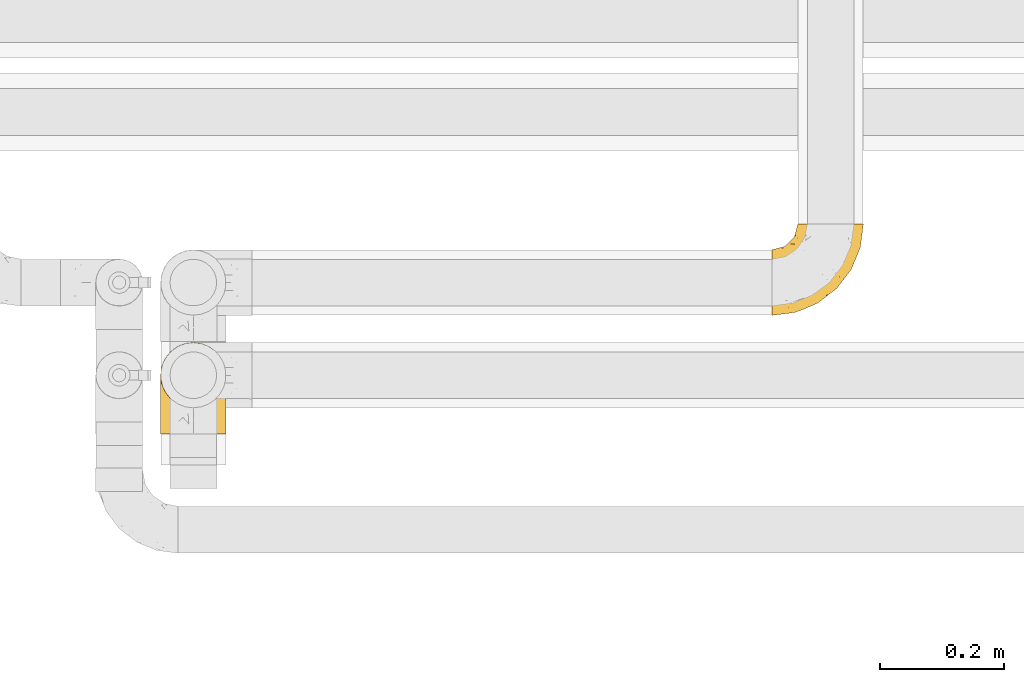
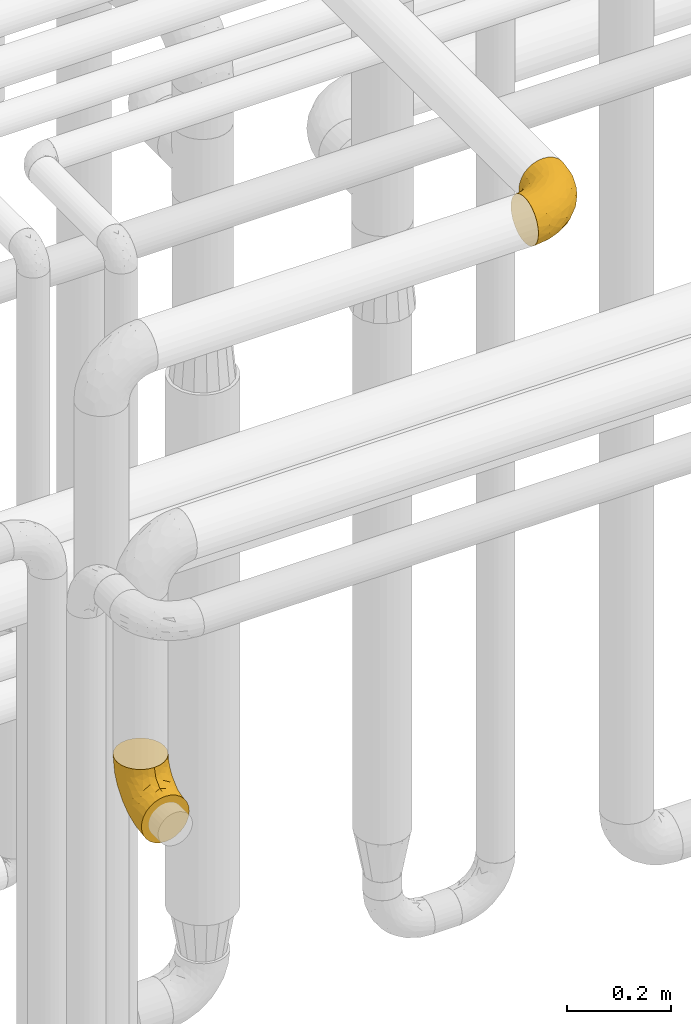
# One storey, part 440 of 827: 2 coverings.
"""IFC2X3 building model written with IfcOpenShell, lengths in millimetres."""

from ifc_helpers import new_model, entity, si_unit, converted_unit, derived_unit, direction, frame, origin, place, context, subcontext, project, spatial, faceted_brep, element, save


model = new_model("IFC2X3")

# Units and contexts
model_context = context("Model", 3, precision=0.01, world=origin(), true_north=direction((6.12303176911189e-17, 1.0)))
body_context = subcontext(model_context, "Body", "Model", "MODEL_VIEW")
ifc_project = project(units=[si_unit("LENGTHUNIT", "METRE", prefix="MILLI"), si_unit("AREAUNIT", "SQUARE_METRE"), si_unit("VOLUMEUNIT", "CUBIC_METRE"), converted_unit("PLANEANGLEUNIT", "DEGREE", entity("IfcRatioMeasure", 0.0174532925199433), si_unit("PLANEANGLEUNIT", "RADIAN"), dimensions=[0, 0, 0, 0, 0, 0, 0]), si_unit("MASSUNIT", "GRAM", prefix="KILO"), derived_unit("MASSDENSITYUNIT", [(si_unit("MASSUNIT", "GRAM", prefix="KILO"), 1), (si_unit("LENGTHUNIT", "METRE"), -3)]), derived_unit("MOMENTOFINERTIAUNIT", [(si_unit("LENGTHUNIT", "METRE"), 4)]), si_unit("TIMEUNIT", "SECOND"), si_unit("FREQUENCYUNIT", "HERTZ"), si_unit("THERMODYNAMICTEMPERATUREUNIT", "DEGREE_CELSIUS"), derived_unit("THERMALTRANSMITTANCEUNIT", [(si_unit("MASSUNIT", "GRAM", prefix="KILO"), 1), (si_unit("THERMODYNAMICTEMPERATUREUNIT", "KELVIN"), -1), (si_unit("TIMEUNIT", "SECOND"), -3)]), derived_unit("VOLUMETRICFLOWRATEUNIT", [(si_unit("LENGTHUNIT", "METRE"), 3), (si_unit("TIMEUNIT", "SECOND"), -1)]), derived_unit("MASSFLOWRATEUNIT", [(si_unit("MASSUNIT", "GRAM", prefix="KILO"), 1), (si_unit("TIMEUNIT", "SECOND"), -1)]), derived_unit("ROTATIONALFREQUENCYUNIT", [(si_unit("TIMEUNIT", "SECOND"), -1)]), si_unit("ELECTRICCURRENTUNIT", "AMPERE"), si_unit("ELECTRICVOLTAGEUNIT", "VOLT"), si_unit("POWERUNIT", "WATT"), si_unit("FORCEUNIT", "NEWTON", prefix="KILO"), si_unit("ILLUMINANCEUNIT", "LUX"), si_unit("LUMINOUSFLUXUNIT", "LUMEN"), si_unit("LUMINOUSINTENSITYUNIT", "CANDELA"), derived_unit("USERDEFINED", [(si_unit("MASSUNIT", "GRAM", prefix="KILO"), -1), (si_unit("LENGTHUNIT", "METRE"), -2), (si_unit("TIMEUNIT", "SECOND"), 3), (si_unit("LUMINOUSFLUXUNIT", "LUMEN"), 1)]), derived_unit("LINEARVELOCITYUNIT", [(si_unit("LENGTHUNIT", "METRE"), 1), (si_unit("TIMEUNIT", "SECOND"), -1)]), si_unit("PRESSUREUNIT", "PASCAL"), derived_unit("USERDEFINED", [(si_unit("LENGTHUNIT", "METRE"), -2), (si_unit("MASSUNIT", "GRAM", prefix="KILO"), 1), (si_unit("TIMEUNIT", "SECOND"), -2)]), derived_unit("LINEARFORCEUNIT", [(si_unit("MASSUNIT", "GRAM", prefix="KILO"), 1), (si_unit("LENGTHUNIT", "METRE"), 1), (si_unit("TIMEUNIT", "SECOND"), -2), (si_unit("LENGTHUNIT", "METRE"), -1)]), derived_unit("PLANARFORCEUNIT", [(si_unit("MASSUNIT", "GRAM", prefix="KILO"), 1), (si_unit("LENGTHUNIT", "METRE"), 1), (si_unit("TIMEUNIT", "SECOND"), -2), (si_unit("LENGTHUNIT", "METRE"), -2)])], contexts=[model_context])

# Site, building, storey
site_placement = place(None, origin())
site = spatial("IfcSite", under=ifc_project, at=site_placement, CompositionType="ELEMENT")
building_placement = place(site_placement, origin())
building = spatial("IfcBuilding", under=site, at=building_placement, CompositionType="ELEMENT")
storey_placement = place(building_placement, frame((0.0, 0.0, 28200.0)))
storey = spatial("IfcBuildingStorey", under=building, at=storey_placement, Name="08", CompositionType="ELEMENT", Elevation=28200.0)

# Coverings
covering_1_placement = place(storey_placement, frame((56690.79, 15591.56, 3345.35)))
element("IfcCovering", 1, at=covering_1_placement, inside=storey, Name=":ADSK_", ObjectType=":ADSK_", PredefinedType="INSULATION", context=body_context, shape_type="Brep", body=[
    faceted_brep([(148.32, 149.65, 66.44), (149.65, 149.65, 54.65), (148.31, 149.65, 42.84), (144.39, 149.65, 31.62), (138.06, 149.65, 21.56), (129.66, 149.65, 13.16), (119.6, 149.65, 6.84), (108.39, 149.65, 2.92), (96.6, 149.65, 1.6), (84.79, 149.65, 2.93), (73.57, 149.65, 6.85), (63.51, 149.65, 13.18), (55.11, 149.65, 21.58), (48.79, 149.65, 31.64), (44.87, 149.65, 42.85), (43.55, 149.65, 54.65), (44.88, 149.65, 66.46), (48.8, 149.65, 77.67), (55.13, 149.65, 87.73), (63.53, 149.65, 96.13), (73.59, 149.65, 102.45), (84.8, 149.65, 106.37), (96.6, 149.65, 107.7), (108.41, 149.65, 106.36), (119.62, 149.65, 102.44), (129.68, 149.65, 96.11), (138.08, 149.65, 87.71), (144.4, 149.65, 77.65), (1.6, 105.89, 40.91), (1.6, 100.59, 28.12), (1.6, 92.16, 17.13), (1.6, 81.17, 8.7), (1.6, 68.38, 3.4), (1.6, 54.65, 1.6), (1.6, 40.91, 3.4), (1.6, 28.12, 8.7), (1.6, 17.13, 17.13), (1.6, 8.7, 28.12), (1.6, 3.4, 40.91), (1.6, 1.6, 54.65), (1.6, 3.4, 68.38), (1.6, 8.7, 81.17), (1.6, 17.13, 92.16), (1.6, 28.12, 100.59), (1.6, 40.91, 105.89), (1.6, 54.65, 107.7), (1.6, 68.38, 105.89), (1.6, 81.17, 100.59), (1.6, 92.16, 92.16), (1.6, 100.59, 81.17), (1.6, 105.89, 68.38), (1.6, 107.7, 54.65), (27.97, 14.05, 85.53), (37.09, 9.45, 73.42), (58.27, 22.36, 83.77), (27.13, 4.7, 64.22), (39.91, 6.64, 54.65), (109.11, 81.47, 96.72), (94.41, 56.83, 93.36), (110.94, 64.02, 84.47), (89.69, 34.04, 71.37), (75.62, 21.43, 54.65), (106.28, 44.96, 54.65), (60.12, 49.8, 103.47), (41.41, 35.43, 100.91), (63.22, 42.1, 99.1), (32.05, 43.59, 105.43), (52.13, 57.88, 106.79), (123.27, 91.8, 89.81), (129.32, 88.01, 79.59), (138.3, 115.65, 81.29), (62.95, 18.94, 74.01), (55.89, 12.83, 64.14), (37.4, 24.96, 94.75), (144.6, 111.33, 54.65), (142.66, 113.8, 70.74), (117.85, 60.89, 68.3), (134.01, 86.24, 66.05), (89.25, 65.84, 100.73), (103.34, 124.58, 106.78), (113.52, 121.36, 103.6), (57.43, 72.79, 107.7), (44.19, 66.04, 107.7), (30.95, 59.29, 107.7), (77.98, 73.26, 106.07), (132.66, 121.69, 90.59), (121.52, 109.82, 97.43), (86.93, 40.11, 84.51), (68.4, 36.57, 93.3), (78.45, 93.81, 107.7), (67.94, 83.3, 107.7), (94.53, 136.6, 107.7), (91.95, 120.29, 107.7), (93.36, 99.11, 106.79), (85.2, 107.05, 107.7), (101.45, 91.12, 103.47), (129.81, 75.62, 54.65), (16.27, 56.97, 107.7), (42.46, 126.65, 76.99), (40.4, 116.55, 84.28), (49.71, 120.09, 91.11), (39.4, 76.06, 106.26), (31.26, 83.69, 102.6), (27.7, 71.88, 106.08), (16.7, 66.92, 106.56), (70.67, 110.43, 105.36), (81.69, 121.31, 106.74), (16.68, 81.0, 101.59), (22.57, 113.32, 54.65), (14.26, 111.09, 54.65), (17.68, 109.14, 67.71), (19.58, 95.86, 91.36), (33.49, 99.07, 94.33), (33.01, 106.92, 87.1), (40.69, 131.39, 65.84), (40.15, 136.98, 54.65), (37.93, 128.67, 54.65), (31.04, 117.07, 68.92), (45.29, 96.39, 100.82), (23.55, 106.61, 79.83), (11.36, 103.72, 77.13), (59.1, 92.14, 105.9), (57.42, 107.13, 101.53), (68.96, 98.03, 106.72), (20.38, 88.38, 97.75), (72.46, 130.66, 103.08), (83.66, 135.45, 106.39), (60.66, 123.57, 98.1), (61.01, 137.75, 95.02), (51.85, 133.2, 86.9), (46.07, 138.8, 74.42), (30.25, 120.99, 54.65), (46.65, 84.53, 105.28), (43.0, 108.72, 92.87), (19.58, 95.86, 17.93), (72.44, 130.67, 6.22), (17.67, 109.13, 41.58), (78.45, 93.81, 1.6), (68.97, 98.02, 2.57), (70.65, 110.43, 3.94), (40.69, 131.4, 43.46), (42.45, 126.66, 32.32), (31.04, 117.08, 40.38), (42.99, 108.74, 16.44), (45.18, 96.31, 8.47), (33.46, 99.11, 15.01), (60.64, 123.58, 11.21), (57.37, 107.12, 7.78), (57.43, 72.79, 1.6), (44.19, 66.04, 1.6), (39.35, 76.07, 3.04), (16.27, 56.97, 1.6), (16.7, 66.92, 2.73), (91.95, 120.29, 1.6), (85.2, 107.05, 1.6), (81.68, 121.26, 2.55), (46.68, 84.46, 3.98), (31.26, 83.69, 6.69), (16.68, 81.0, 7.7), (27.7, 71.88, 3.21), (60.99, 137.76, 14.28), (51.84, 133.21, 22.42), (40.41, 116.58, 25.02), (49.72, 120.1, 18.18), (46.06, 138.81, 34.89), (94.53, 136.6, 1.6), (11.35, 103.72, 32.17), (33.02, 106.96, 22.23), (83.65, 135.44, 2.91), (20.38, 88.38, 11.54), (67.94, 83.3, 1.6), (23.53, 106.6, 29.46), (59.12, 92.12, 3.38), (30.95, 59.29, 1.6), (58.27, 22.36, 25.52), (27.97, 14.05, 23.76), (37.4, 24.96, 14.54), (41.41, 35.43, 8.38), (27.21, 4.71, 45.07), (37.09, 9.45, 35.87), (53.2, 11.79, 45.14), (52.13, 57.88, 2.5), (103.34, 124.57, 2.51), (113.5, 121.37, 5.68), (101.45, 91.12, 5.82), (94.41, 56.83, 15.93), (109.08, 81.48, 12.54), (110.95, 64.05, 24.81), (93.36, 99.11, 2.5), (77.98, 73.26, 3.22), (32.05, 43.59, 3.86), (64.63, 19.5, 35.85), (123.25, 91.8, 19.47), (132.65, 121.7, 18.68), (129.32, 88.04, 29.68), (139.96, 123.34, 27.95), (117.85, 60.89, 40.99), (89.69, 34.04, 37.92), (121.51, 109.85, 11.85), (63.23, 42.1, 10.19), (89.17, 65.78, 8.55), (142.66, 113.81, 38.53), (68.4, 36.57, 15.99), (86.94, 40.12, 24.79), (60.12, 49.8, 5.82), (133.2, 86.08, 40.56)], [[[0, 1, 2, 3, 4, 5, 6, 7, 8, 9, 10, 11, 12, 13, 14, 15, 16, 17, 18, 19, 20, 21, 22, 23, 24, 25, 26, 27]], [[28, 29, 30, 31, 32, 33, 34, 35, 36, 37, 38, 39, 40, 41, 42, 43, 44, 45, 46, 47, 48, 49, 50, 51]], [[52, 53, 54]], [[55, 39, 56]], [[57, 58, 59]], [[60, 61, 62]], [[63, 64, 65]], [[66, 63, 67]], [[68, 69, 70]], [[53, 71, 54]], [[41, 40, 53]], [[53, 72, 71]], [[73, 42, 52]], [[42, 41, 52]], [[74, 0, 75]], [[69, 76, 77]], [[43, 73, 64]], [[45, 44, 66]], [[57, 78, 58]], [[23, 79, 80]], [[67, 81, 82, 83]], [[67, 84, 81]], [[24, 23, 80]], [[25, 85, 26]], [[86, 85, 25]], [[42, 73, 43]], [[0, 27, 75]], [[25, 24, 86]], [[70, 26, 85]], [[0, 74, 1]], [[68, 85, 86]], [[66, 64, 63]], [[60, 59, 87]], [[54, 87, 88]], [[76, 60, 62]], [[84, 89, 90, 81]], [[79, 22, 91, 92]], [[77, 74, 75]], [[93, 92, 94, 89]], [[80, 86, 24]], [[40, 55, 53]], [[76, 59, 60]], [[93, 84, 95]], [[76, 62, 96]], [[55, 72, 53]], [[70, 27, 26]], [[75, 70, 69]], [[78, 84, 63]], [[93, 79, 92]], [[95, 86, 80]], [[77, 76, 96]], [[59, 69, 68]], [[57, 68, 86]], [[68, 57, 59]], [[59, 58, 87]], [[76, 69, 59]], [[88, 87, 58]], [[87, 54, 71]], [[86, 95, 57]], [[78, 57, 95]], [[84, 78, 95]], [[78, 63, 65]], [[58, 78, 65]], [[54, 88, 73]], [[84, 93, 89]], [[79, 95, 80]], [[79, 93, 95]], [[22, 79, 23]], [[66, 83, 97, 45]], [[84, 67, 63]], [[83, 66, 67]], [[64, 44, 43]], [[64, 66, 44]], [[65, 73, 88]], [[53, 52, 41]], [[73, 52, 54]], [[73, 65, 64]], [[65, 88, 58]], [[39, 55, 40]], [[72, 55, 56]], [[56, 61, 72]], [[60, 72, 61]], [[72, 60, 71]], [[87, 71, 60]], [[27, 70, 75]], [[68, 70, 85]], [[74, 77, 96]], [[69, 77, 75]], [[98, 99, 100]], [[46, 45, 97]], [[101, 102, 103]], [[103, 104, 83]], [[105, 94, 106]], [[107, 103, 102]], [[108, 109, 51, 110]], [[111, 112, 113]], [[114, 115, 116]], [[47, 104, 107]], [[110, 117, 108]], [[49, 48, 111]], [[102, 118, 112]], [[119, 120, 111]], [[50, 49, 120]], [[121, 122, 118]], [[105, 123, 89]], [[124, 48, 107]], [[20, 19, 125]], [[121, 81, 90]], [[117, 119, 99]], [[21, 20, 126]], [[22, 21, 91]], [[105, 125, 127]], [[110, 51, 50]], [[19, 128, 125]], [[16, 15, 115]], [[129, 98, 100]], [[126, 91, 21]], [[128, 129, 127]], [[122, 123, 105]], [[114, 117, 98]], [[17, 16, 130]], [[18, 128, 19]], [[129, 18, 17]], [[125, 106, 126]], [[115, 114, 16]], [[130, 129, 17]], [[114, 98, 130]], [[117, 116, 131, 108]], [[99, 119, 113]], [[122, 121, 123]], [[92, 126, 106]], [[105, 127, 122]], [[132, 121, 118]], [[114, 130, 16]], [[129, 130, 98]], [[50, 120, 110]], [[129, 128, 18]], [[125, 128, 127]], [[125, 126, 20]], [[91, 126, 92]], [[105, 89, 94]], [[105, 106, 125]], [[94, 92, 106]], [[100, 122, 127]], [[118, 122, 133]], [[112, 118, 133]], [[132, 118, 102]], [[132, 102, 101]], [[81, 121, 132]], [[82, 103, 83]], [[132, 101, 81]], [[104, 47, 46]], [[124, 107, 102]], [[48, 47, 107]], [[113, 112, 133]], [[112, 111, 124]], [[99, 113, 133]], [[111, 113, 119]], [[99, 133, 100]], [[117, 99, 98]], [[122, 100, 133]], [[127, 129, 100]], [[103, 82, 101]], [[81, 101, 82]], [[112, 124, 102]], [[48, 124, 111]], [[104, 103, 107]], [[46, 97, 104]], [[111, 120, 49]], [[83, 104, 97]], [[110, 120, 119]], [[117, 110, 119]], [[116, 117, 114]], [[89, 123, 90]], [[90, 123, 121]], [[30, 29, 134]], [[11, 10, 135]], [[51, 109, 108, 136]], [[137, 138, 139]], [[140, 141, 142]], [[143, 144, 145]], [[146, 139, 147]], [[148, 149, 150]], [[151, 32, 152]], [[153, 154, 155]], [[156, 150, 157]], [[158, 157, 159]], [[108, 142, 136]], [[31, 158, 152]], [[160, 161, 12]], [[162, 163, 143]], [[140, 142, 116]], [[142, 141, 162]], [[14, 164, 140]], [[14, 140, 115]], [[9, 8, 165]], [[160, 12, 11]], [[141, 164, 161]], [[13, 12, 161]], [[14, 115, 15]], [[28, 166, 29]], [[135, 139, 146]], [[141, 163, 162]], [[135, 146, 160]], [[143, 167, 162]], [[29, 166, 134]], [[116, 142, 108, 131]], [[165, 153, 168]], [[10, 9, 168]], [[168, 135, 10]], [[138, 147, 139]], [[158, 169, 157]], [[14, 13, 164]], [[116, 115, 140]], [[145, 167, 143]], [[135, 160, 11]], [[168, 153, 155]], [[138, 137, 170]], [[157, 144, 156]], [[147, 144, 143]], [[161, 164, 13]], [[140, 164, 141]], [[142, 171, 136]], [[136, 171, 166]], [[161, 160, 146]], [[165, 168, 9]], [[155, 139, 135]], [[139, 154, 137]], [[168, 155, 135]], [[139, 155, 154]], [[144, 147, 172]], [[163, 147, 143]], [[156, 144, 172]], [[157, 169, 145]], [[172, 148, 156]], [[173, 159, 149]], [[159, 157, 150]], [[152, 159, 173]], [[159, 152, 158]], [[31, 30, 158]], [[169, 30, 134]], [[157, 145, 144]], [[167, 134, 171]], [[134, 167, 145]], [[171, 142, 162]], [[162, 167, 171]], [[163, 141, 161]], [[161, 146, 163]], [[147, 163, 146]], [[148, 150, 156]], [[149, 159, 150]], [[30, 169, 158]], [[145, 169, 134]], [[151, 33, 32]], [[31, 152, 32]], [[152, 173, 151]], [[28, 51, 136]], [[134, 166, 171]], [[28, 136, 166]], [[138, 170, 172]], [[147, 138, 172]], [[148, 172, 170]], [[174, 175, 176]], [[35, 34, 177]], [[178, 179, 180]], [[181, 173, 149, 148]], [[182, 183, 184]], [[185, 186, 187]], [[188, 189, 137]], [[190, 33, 151, 173]], [[191, 179, 174]], [[34, 190, 177]], [[39, 38, 178]], [[192, 193, 194]], [[4, 3, 195]], [[175, 179, 37]], [[38, 37, 179]], [[35, 176, 36]], [[196, 62, 197]], [[181, 190, 173]], [[37, 36, 175]], [[183, 6, 198]], [[189, 148, 170, 137]], [[185, 199, 200]], [[3, 2, 201]], [[202, 185, 203]], [[8, 7, 182]], [[200, 184, 186]], [[183, 7, 6]], [[181, 189, 204]], [[200, 189, 184]], [[5, 198, 6]], [[187, 203, 185]], [[195, 3, 201]], [[205, 196, 194]], [[62, 61, 197]], [[186, 198, 192]], [[180, 179, 191]], [[2, 1, 74]], [[198, 193, 192]], [[193, 5, 4]], [[194, 193, 195]], [[2, 74, 201]], [[5, 193, 198]], [[205, 74, 96]], [[188, 137, 154, 153]], [[62, 196, 96]], [[56, 178, 180]], [[198, 184, 183]], [[184, 188, 182]], [[203, 197, 191]], [[205, 194, 201]], [[187, 192, 194]], [[192, 187, 186]], [[194, 196, 187]], [[197, 187, 196]], [[197, 203, 187]], [[202, 174, 176]], [[200, 186, 185]], [[184, 198, 186]], [[199, 185, 202]], [[189, 200, 204]], [[174, 202, 203]], [[176, 177, 199]], [[189, 181, 148]], [[190, 181, 204]], [[190, 204, 177]], [[190, 34, 33]], [[188, 153, 182]], [[189, 188, 184]], [[182, 153, 165, 8]], [[183, 182, 7]], [[199, 177, 204]], [[35, 177, 176]], [[176, 175, 36]], [[179, 175, 174]], [[200, 199, 204]], [[176, 199, 202]], [[203, 191, 174]], [[180, 197, 61]], [[197, 180, 191]], [[61, 56, 180]], [[39, 178, 56]], [[38, 179, 178]], [[194, 195, 201]], [[4, 195, 193]], [[74, 205, 201]], [[96, 196, 205]]]),
])
covering_2_placement = place(storey_placement, frame((55701.2, 15399.61, 2420.35)))
element("IfcCovering", 2, at=covering_2_placement, inside=storey, Name=":ADSK_", ObjectType=":ADSK_", PredefinedType="INSULATION", context=body_context, shape_type="Brep", body=[
    faceted_brep([(42.85, 1.6, 2.92), (54.65, 1.6, 1.6), (66.46, 1.6, 2.93), (77.67, 1.6, 6.85), (87.73, 1.6, 13.18), (96.13, 1.6, 21.58), (102.45, 1.6, 31.64), (106.37, 1.6, 42.85), (107.7, 1.6, 54.65), (106.36, 1.6, 66.46), (102.44, 1.6, 77.67), (96.11, 1.6, 87.73), (87.71, 1.6, 96.13), (77.65, 1.6, 102.45), (66.44, 1.6, 106.37), (54.65, 1.6, 107.7), (42.84, 1.6, 106.36), (31.62, 1.6, 102.44), (21.56, 1.6, 96.11), (13.16, 1.6, 87.71), (6.84, 1.6, 77.65), (2.92, 1.6, 66.44), (1.6, 1.6, 54.65), (2.93, 1.6, 42.84), (6.85, 1.6, 31.62), (13.18, 1.6, 21.56), (21.58, 1.6, 13.16), (31.64, 1.6, 6.84), (68.38, 45.35, 149.65), (81.17, 50.65, 149.65), (92.16, 59.08, 149.65), (100.59, 70.07, 149.65), (105.89, 82.86, 149.65), (107.7, 96.6, 149.65), (105.89, 110.33, 149.65), (100.59, 123.12, 149.65), (92.16, 134.11, 149.65), (81.17, 142.54, 149.65), (68.38, 147.84, 149.65), (54.65, 149.65, 149.65), (40.91, 147.84, 149.65), (28.12, 142.54, 149.65), (17.13, 134.11, 149.65), (8.7, 123.12, 149.65), (3.4, 110.33, 149.65), (1.6, 96.6, 149.65), (3.4, 82.86, 149.65), (8.7, 70.07, 149.65), (17.13, 59.08, 149.65), (28.12, 50.65, 149.65), (40.91, 45.35, 149.65), (54.65, 43.55, 149.65), (23.76, 137.19, 123.27), (35.87, 141.79, 114.15), (25.52, 128.89, 92.97), (45.07, 146.54, 124.11), (54.65, 144.6, 111.33), (12.57, 69.77, 42.13), (15.93, 94.41, 56.83), (24.82, 87.22, 40.31), (37.92, 117.2, 61.55), (54.65, 129.81, 75.62), (54.65, 106.28, 44.96), (5.82, 101.45, 91.12), (8.38, 115.81, 109.83), (10.19, 109.14, 88.02), (3.86, 107.65, 119.19), (2.5, 93.36, 99.11), (19.48, 59.44, 27.97), (29.7, 63.23, 21.92), (28.0, 35.59, 12.94), (35.28, 132.3, 88.29), (45.15, 138.41, 95.35), (14.54, 126.28, 113.84), (54.65, 39.91, 6.64), (38.55, 37.44, 8.58), (40.99, 90.35, 33.39), (43.24, 65.0, 17.23), (8.56, 85.4, 61.99), (2.51, 26.66, 47.9), (5.69, 29.88, 37.72), (1.6, 78.45, 93.81), (1.6, 85.2, 107.05), (1.6, 91.95, 120.29), (3.22, 77.98, 73.26), (18.7, 29.55, 18.58), (11.86, 41.42, 29.72), (24.78, 111.13, 64.31), (15.99, 114.67, 82.84), (1.6, 57.43, 72.79), (1.6, 67.94, 83.3), (1.6, 14.64, 56.71), (1.6, 30.95, 59.29), (2.5, 52.13, 57.88), (1.6, 44.19, 66.04), (5.82, 60.12, 49.8), (54.65, 75.62, 21.43), (1.6, 94.27, 134.97), (32.3, 24.59, 108.79), (25.01, 34.69, 110.84), (18.18, 31.15, 101.53), (3.03, 75.18, 111.84), (6.69, 67.55, 119.98), (3.21, 79.36, 123.54), (2.73, 84.32, 134.54), (3.93, 40.81, 80.57), (2.55, 29.93, 69.55), (7.7, 70.24, 134.56), (54.65, 37.93, 128.67), (54.65, 40.15, 136.98), (41.58, 42.1, 133.56), (17.93, 55.38, 131.66), (14.97, 52.17, 117.75), (22.2, 44.32, 118.23), (43.45, 19.85, 110.55), (54.65, 14.26, 111.09), (54.65, 22.57, 113.32), (40.37, 34.17, 120.2), (8.47, 54.85, 105.95), (29.46, 44.63, 127.69), (32.17, 47.52, 139.88), (3.39, 59.1, 92.14), (7.76, 44.11, 93.82), (2.57, 53.21, 82.28), (11.54, 62.86, 130.86), (6.21, 20.58, 78.78), (2.9, 15.79, 67.58), (11.19, 27.67, 90.58), (14.27, 13.49, 90.23), (22.4, 18.04, 99.39), (34.87, 12.44, 105.17), (54.65, 30.25, 120.99), (4.01, 66.71, 104.59), (16.42, 42.52, 108.24), (91.36, 55.38, 131.66), (103.07, 20.57, 78.8), (67.71, 42.11, 133.57), (107.7, 57.43, 72.79), (106.72, 53.22, 82.27), (105.35, 40.81, 80.59), (65.83, 19.85, 110.55), (76.97, 24.58, 108.79), (68.91, 34.16, 120.2), (92.85, 42.5, 108.25), (100.82, 54.93, 106.06), (94.28, 52.13, 117.78), (98.08, 27.66, 90.6), (101.51, 44.12, 93.87), (107.7, 78.45, 93.81), (107.7, 85.2, 107.05), (106.25, 75.17, 111.89), (107.7, 94.27, 134.97), (106.56, 84.32, 134.54), (107.7, 30.95, 59.29), (107.7, 44.19, 66.04), (106.74, 29.98, 69.56), (105.31, 66.78, 104.56), (102.6, 67.55, 119.98), (101.59, 70.24, 134.56), (106.08, 79.36, 123.54), (95.01, 13.48, 90.25), (86.87, 18.03, 99.4), (84.27, 34.66, 110.83), (91.11, 31.14, 101.52), (74.4, 12.43, 105.18), (107.7, 14.64, 56.71), (77.12, 47.52, 139.89), (87.06, 44.28, 118.22), (106.38, 15.8, 67.6), (97.75, 62.86, 130.86), (107.7, 67.94, 83.3), (79.83, 44.64, 127.71), (105.91, 59.12, 92.12), (107.7, 91.95, 120.29), (83.77, 128.89, 92.97), (85.53, 137.19, 123.27), (94.75, 126.28, 113.84), (100.91, 115.81, 109.83), (64.22, 146.53, 124.03), (73.42, 141.79, 114.15), (64.15, 139.45, 98.04), (106.79, 93.36, 99.11), (106.79, 26.67, 47.9), (103.61, 29.87, 37.74), (103.47, 60.12, 49.8), (93.36, 94.41, 56.83), (96.75, 69.76, 42.16), (84.48, 87.19, 40.3), (106.79, 52.13, 57.88), (106.07, 77.98, 73.26), (105.43, 107.65, 119.19), (73.44, 131.74, 86.61), (89.82, 59.44, 27.99), (90.61, 29.54, 18.59), (79.61, 63.2, 21.92), (81.34, 27.9, 11.28), (68.3, 90.35, 33.39), (71.37, 117.2, 61.55), (97.44, 41.39, 29.73), (99.1, 109.14, 88.01), (100.74, 85.46, 62.08), (70.76, 37.43, 8.58), (93.3, 114.67, 82.84), (84.5, 111.12, 64.3), (103.47, 101.45, 91.12), (68.73, 65.16, 18.05)], [[[0, 1, 2, 3, 4, 5, 6, 7, 8, 9, 10, 11, 12, 13, 14, 15, 16, 17, 18, 19, 20, 21, 22, 23, 24, 25, 26, 27]], [[28, 29, 30, 31, 32, 33, 34, 35, 36, 37, 38, 39, 40, 41, 42, 43, 44, 45, 46, 47, 48, 49, 50, 51]], [[52, 53, 54]], [[55, 39, 56]], [[57, 58, 59]], [[60, 61, 62]], [[63, 64, 65]], [[66, 63, 67]], [[68, 69, 70]], [[53, 71, 54]], [[41, 40, 53]], [[53, 72, 71]], [[73, 42, 52]], [[42, 41, 52]], [[74, 0, 75]], [[69, 76, 77]], [[43, 73, 64]], [[45, 44, 66]], [[57, 78, 58]], [[23, 79, 80]], [[67, 81, 82, 83]], [[67, 84, 81]], [[24, 23, 80]], [[25, 85, 26]], [[86, 85, 25]], [[42, 73, 43]], [[0, 27, 75]], [[25, 24, 86]], [[70, 26, 85]], [[0, 74, 1]], [[68, 85, 86]], [[66, 64, 63]], [[60, 59, 87]], [[54, 87, 88]], [[76, 60, 62]], [[84, 89, 90, 81]], [[79, 22, 91, 92]], [[77, 74, 75]], [[93, 92, 94, 89]], [[80, 86, 24]], [[40, 55, 53]], [[76, 59, 60]], [[93, 84, 95]], [[76, 62, 96]], [[55, 72, 53]], [[70, 27, 26]], [[75, 70, 69]], [[78, 84, 63]], [[93, 79, 92]], [[95, 86, 80]], [[77, 76, 96]], [[59, 69, 68]], [[57, 68, 86]], [[68, 57, 59]], [[59, 58, 87]], [[76, 69, 59]], [[88, 87, 58]], [[87, 54, 71]], [[86, 95, 57]], [[78, 57, 95]], [[84, 78, 95]], [[78, 63, 65]], [[58, 78, 65]], [[54, 88, 73]], [[84, 93, 89]], [[79, 95, 80]], [[79, 93, 95]], [[22, 79, 23]], [[66, 83, 97, 45]], [[84, 67, 63]], [[83, 66, 67]], [[64, 44, 43]], [[64, 66, 44]], [[65, 73, 88]], [[53, 52, 41]], [[73, 52, 54]], [[73, 65, 64]], [[65, 88, 58]], [[39, 55, 40]], [[72, 55, 56]], [[56, 61, 72]], [[60, 72, 61]], [[72, 60, 71]], [[87, 71, 60]], [[27, 70, 75]], [[68, 70, 85]], [[74, 77, 96]], [[69, 77, 75]], [[98, 99, 100]], [[46, 45, 97]], [[101, 102, 103]], [[103, 104, 83]], [[105, 94, 106]], [[107, 103, 102]], [[108, 109, 51, 110]], [[111, 112, 113]], [[114, 115, 116]], [[47, 104, 107]], [[110, 117, 108]], [[49, 48, 111]], [[102, 118, 112]], [[119, 120, 111]], [[50, 49, 120]], [[121, 122, 118]], [[105, 123, 89]], [[124, 48, 107]], [[20, 19, 125]], [[121, 81, 90]], [[117, 119, 99]], [[21, 20, 126]], [[22, 21, 91]], [[105, 125, 127]], [[110, 51, 50]], [[19, 128, 125]], [[16, 15, 115]], [[129, 98, 100]], [[126, 91, 21]], [[128, 129, 127]], [[122, 123, 105]], [[114, 117, 98]], [[17, 16, 130]], [[18, 128, 19]], [[129, 18, 17]], [[125, 106, 126]], [[115, 114, 16]], [[130, 129, 17]], [[114, 98, 130]], [[117, 116, 131, 108]], [[99, 119, 113]], [[122, 121, 123]], [[92, 126, 106]], [[105, 127, 122]], [[132, 121, 118]], [[114, 130, 16]], [[129, 130, 98]], [[50, 120, 110]], [[129, 128, 18]], [[125, 128, 127]], [[125, 126, 20]], [[91, 126, 92]], [[105, 89, 94]], [[105, 106, 125]], [[94, 92, 106]], [[100, 122, 127]], [[118, 122, 133]], [[112, 118, 133]], [[132, 118, 102]], [[132, 102, 101]], [[81, 121, 132]], [[82, 103, 83]], [[132, 101, 81]], [[104, 47, 46]], [[124, 107, 102]], [[48, 47, 107]], [[113, 112, 133]], [[112, 111, 124]], [[99, 113, 133]], [[111, 113, 119]], [[99, 133, 100]], [[117, 99, 98]], [[122, 100, 133]], [[127, 129, 100]], [[103, 82, 101]], [[81, 101, 82]], [[112, 124, 102]], [[48, 124, 111]], [[104, 103, 107]], [[46, 97, 104]], [[111, 120, 49]], [[83, 104, 97]], [[110, 120, 119]], [[117, 110, 119]], [[116, 117, 114]], [[123, 90, 89]], [[90, 123, 121]], [[30, 29, 134]], [[11, 10, 135]], [[51, 109, 108, 136]], [[137, 138, 139]], [[140, 141, 142]], [[143, 144, 145]], [[146, 139, 147]], [[148, 149, 150]], [[151, 32, 152]], [[153, 154, 155]], [[156, 150, 157]], [[158, 157, 159]], [[108, 142, 136]], [[31, 158, 152]], [[160, 161, 12]], [[162, 163, 143]], [[140, 142, 116]], [[142, 141, 162]], [[14, 164, 140]], [[14, 140, 115]], [[9, 8, 165]], [[160, 12, 11]], [[141, 164, 161]], [[13, 12, 161]], [[14, 115, 15]], [[28, 166, 29]], [[135, 139, 146]], [[141, 163, 162]], [[135, 146, 160]], [[143, 167, 162]], [[29, 166, 134]], [[116, 142, 108, 131]], [[165, 153, 168]], [[10, 9, 168]], [[168, 135, 10]], [[138, 147, 139]], [[158, 169, 157]], [[14, 13, 164]], [[116, 115, 140]], [[145, 167, 143]], [[135, 160, 11]], [[168, 153, 155]], [[138, 137, 170]], [[157, 144, 156]], [[147, 144, 143]], [[161, 164, 13]], [[140, 164, 141]], [[142, 171, 136]], [[136, 171, 166]], [[161, 160, 146]], [[165, 168, 9]], [[155, 139, 135]], [[139, 154, 137]], [[168, 155, 135]], [[139, 155, 154]], [[144, 147, 172]], [[163, 147, 143]], [[156, 144, 172]], [[157, 169, 145]], [[172, 148, 156]], [[173, 159, 149]], [[159, 157, 150]], [[152, 159, 173]], [[159, 152, 158]], [[31, 30, 158]], [[169, 30, 134]], [[157, 145, 144]], [[167, 134, 171]], [[134, 167, 145]], [[171, 142, 162]], [[162, 167, 171]], [[163, 141, 161]], [[161, 146, 163]], [[147, 163, 146]], [[148, 150, 156]], [[149, 159, 150]], [[30, 169, 158]], [[145, 169, 134]], [[151, 33, 32]], [[31, 152, 32]], [[152, 173, 151]], [[28, 51, 136]], [[134, 166, 171]], [[28, 136, 166]], [[138, 170, 172]], [[147, 138, 172]], [[148, 172, 170]], [[174, 175, 176]], [[35, 34, 177]], [[178, 179, 180]], [[181, 173, 149, 148]], [[182, 183, 184]], [[185, 186, 187]], [[188, 189, 137]], [[190, 33, 151, 173]], [[191, 179, 174]], [[34, 190, 177]], [[39, 38, 178]], [[192, 193, 194]], [[4, 3, 195]], [[175, 179, 37]], [[38, 37, 179]], [[35, 176, 36]], [[196, 62, 197]], [[181, 190, 173]], [[37, 36, 175]], [[183, 6, 198]], [[189, 148, 170, 137]], [[185, 199, 200]], [[3, 2, 201]], [[202, 185, 203]], [[8, 7, 182]], [[200, 184, 186]], [[183, 7, 6]], [[181, 189, 204]], [[200, 189, 184]], [[5, 198, 6]], [[187, 203, 185]], [[195, 3, 201]], [[205, 196, 194]], [[62, 61, 197]], [[186, 198, 192]], [[180, 179, 191]], [[2, 1, 74]], [[198, 193, 192]], [[193, 5, 4]], [[194, 193, 195]], [[2, 74, 201]], [[5, 193, 198]], [[205, 74, 96]], [[188, 137, 154, 153]], [[62, 196, 96]], [[56, 178, 180]], [[198, 184, 183]], [[184, 188, 182]], [[203, 197, 191]], [[205, 194, 201]], [[187, 192, 194]], [[192, 187, 186]], [[194, 196, 187]], [[197, 187, 196]], [[197, 203, 187]], [[202, 174, 176]], [[200, 186, 185]], [[184, 198, 186]], [[199, 185, 202]], [[189, 200, 204]], [[174, 202, 203]], [[176, 177, 199]], [[189, 181, 148]], [[190, 181, 204]], [[190, 204, 177]], [[190, 34, 33]], [[188, 153, 182]], [[189, 188, 184]], [[182, 153, 165, 8]], [[183, 182, 7]], [[199, 177, 204]], [[35, 177, 176]], [[176, 175, 36]], [[179, 175, 174]], [[200, 199, 204]], [[176, 199, 202]], [[203, 191, 174]], [[180, 197, 61]], [[197, 180, 191]], [[61, 56, 180]], [[39, 178, 56]], [[38, 179, 178]], [[194, 195, 201]], [[4, 195, 193]], [[74, 205, 201]], [[96, 196, 205]]]),
])

save(model, "model.ifc")
